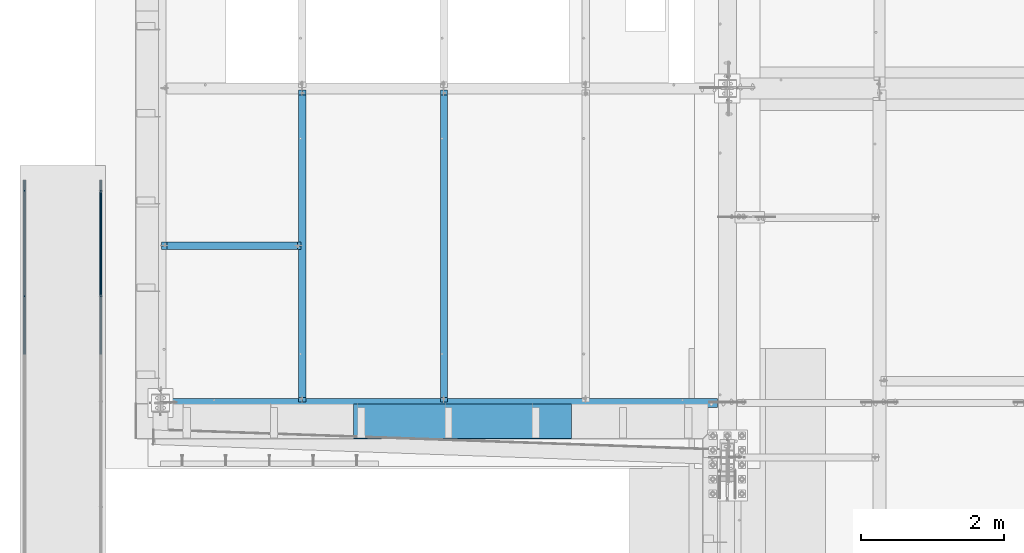
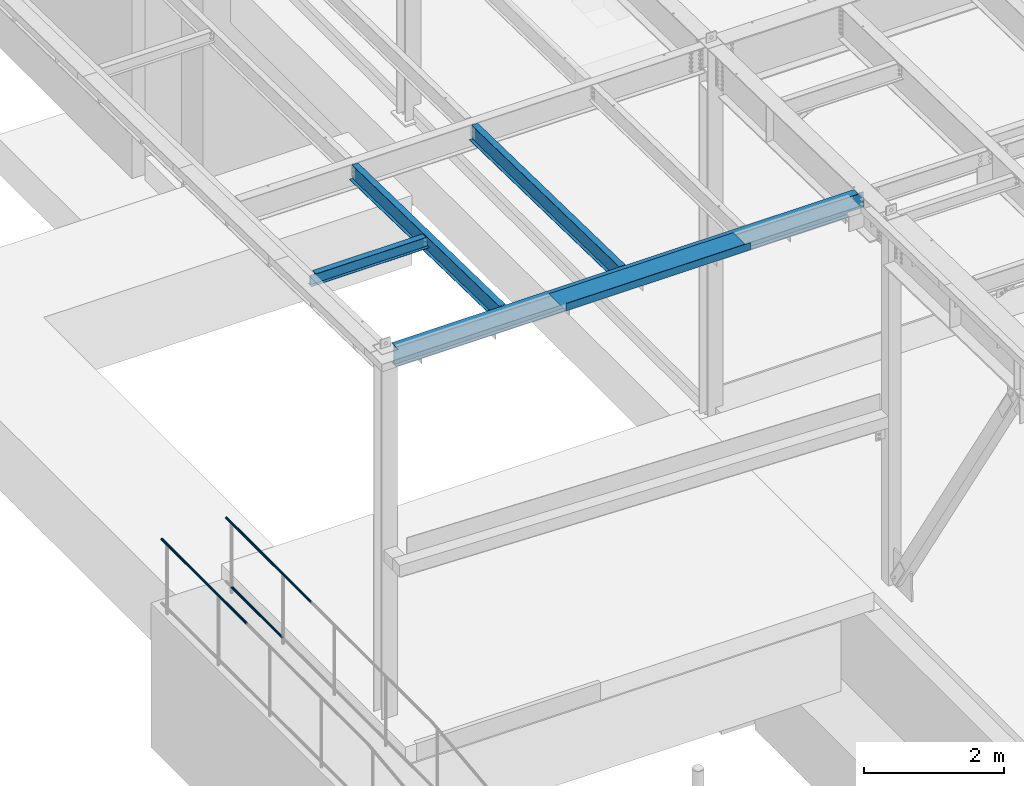
# One storey, part 1047 of 1763: 8 beams, 6 elements without a shape of their own.
"""IFC2X3 building model written with IfcOpenShell, lengths in millimetres."""

from ifc_helpers import new_model, si_unit, frame, origin_with_axes, place, context, subcontext, project, spatial, faceted_brep, material, type_object, element, aggregate, save


model = new_model("IFC2X3")

# Units and contexts
model_context = context("Model", 3, precision=1e-05, world=origin_with_axes())
body_context = subcontext(model_context, "Body", "Model", "MODEL_VIEW")
ifc_project = project(units=[si_unit("LENGTHUNIT", "METRE", prefix="MILLI"), si_unit("AREAUNIT", "SQUARE_METRE"), si_unit("VOLUMEUNIT", "CUBIC_METRE"), si_unit("MASSUNIT", "GRAM", prefix="KILO"), si_unit("TIMEUNIT", "SECOND"), si_unit("PLANEANGLEUNIT", "RADIAN"), si_unit("SOLIDANGLEUNIT", "STERADIAN"), si_unit("THERMODYNAMICTEMPERATUREUNIT", "DEGREE_CELSIUS"), si_unit("LUMINOUSINTENSITYUNIT", "LUMEN")], contexts=[model_context])

# Site, building, storey
site_placement = place(None, origin_with_axes())
site = spatial("IfcSite", under=ifc_project, at=site_placement, CompositionType="ELEMENT")
building_placement = place(site_placement, origin_with_axes())
building = spatial("IfcBuilding", under=site, at=building_placement, Name="Undefined", CompositionType="ELEMENT")
storey_placement = place(building_placement, origin_with_axes())
storey = spatial("IfcBuildingStorey", under=building, at=storey_placement, Name="Undefined", CompositionType="ELEMENT", Elevation=0.0)

# Assembly, beam
assembly_1_placement = place(storey_placement, origin_with_axes())
assembly_1 = element("IfcElementAssembly", 1, at=assembly_1_placement, inside=storey, Name="GUARDRAIL", AssemblyPlace="NOTDEFINED", PredefinedType="RIGID_FRAME")
ifc_material_1 = material(Name="STEEL/A513")
beam_type_1 = type_object("IfcBeamType", PredefinedType="NOTDEFINED")
beam_1_placement = place(assembly_1_placement, frame((-97200.6527017878, 12414.0437130928, 7149.43160350605), z_axis=(1.0, 0.0, 0.0), x_axis=(0.0, -1.0, 0.0)))
beam_1 = element("IfcBeam", 2, at=beam_1_placement, type_object=beam_type_1, material=ifc_material_1, Name="GUARDRAIL", context=body_context, shape_type="Brep", body=[
    faceted_brep([(0.0, -19.0500000000029, 0.0), (0.0, -16.4977839420899, -9.52500000000146), (2438.33764459851, -16.4980626778533, -9.52499999999418), (2438.33764430676, -19.05027873576, 0.0), (0.0, -9.52499999999418, -16.4977839420935), (2438.3376453956, -9.52527873575946, -16.4977839420899), (1.45519152283669e-11, 1.81898940354586e-12, -19.0499999999993), (2438.33764648444, -0.000278735759820847, -19.0500000000029), (0.0, 9.52499999999418, -16.4977839420935), (2438.33764757328, 9.52472126424072, -16.4977839420899), (0.0, 16.4977839420899, -9.52500000000146), (2438.33764837036, 16.4975052063346, -9.52499999999418), (0.0, 19.0500000000029, 0.0), (2438.33764866212, 19.0497212642413, 0.0), (0.0, 16.4977839420899, 9.52500000000146), (2438.33764837036, 16.4975052063346, 9.52499999999418), (0.0, 9.52499999999418, 16.4977839420935), (2438.33764757328, 9.52472126424072, 16.4977839420899), (1.45519152283669e-11, 1.81898940354586e-12, 19.0499999999993), (2438.33764648444, -0.000278735759820847, 19.0500000000029), (0.0, -9.52499999999418, 16.4977839420935), (2438.3376453956, -9.52527873575946, 16.4977839420899), (0.0, -16.4977839420899, 9.52500000000146), (2438.33764459851, -16.4980626778533, 9.52499999999418), (4.71409293822944e-08, -15.3669999999984, 0.0), (-1.81898940354586e-12, -13.3082123799541, 7.68349999999919), (2438.33764496312, -13.3084911157148, 7.68349999999919), (2438.33764472778, -15.36727873576, 0.0), (-3.63797880709171e-12, -7.68349999999919, 13.3082123799531), (2438.33764560611, -7.68377873575992, 13.3082123799541), (-1.81898940354586e-12, 0.0, 15.3669999999966), (2438.33764648444, -0.000278735759820847, 15.3669999999984), (-3.63797880709171e-12, 7.68349999999919, 13.3082123799531), (2438.33764736277, 7.68322126424027, 13.3082123799541), (-1.81898940354586e-12, 13.3082123799541, 7.68349999999919), (2438.33764800575, 13.3079336441961, 7.68349999999919), (4.71409293822944e-08, 15.3669999999984, 0.0), (2438.3376482411, 15.3667212642404, 0.0), (3.63797880709171e-12, 13.3082123799541, -7.68349999999737), (2438.33764800575, 13.3079336441961, -7.68349999999919), (3.63797880709171e-12, 7.68349999999919, -13.3082123799522), (2438.33764736277, 7.68322126424027, -13.3082123799541), (3.63797880709171e-12, 0.0, -15.3669999999956), (2438.33764648444, -0.000278735759820847, -15.3669999999984), (3.63797880709171e-12, -7.68349999999919, -13.3082123799522), (2438.33764560611, -7.68377873575992, -13.3082123799541), (3.63797880709171e-12, -13.3082123799541, -7.68349999999737), (2438.33764496312, -13.3084911157148, -7.68349999999919)], [[[0, 1, 2, 3]], [[1, 4, 5, 2]], [[4, 6, 7, 5]], [[6, 8, 9, 7]], [[8, 10, 11, 9]], [[10, 12, 13, 11]], [[12, 14, 15, 13]], [[14, 16, 17, 15]], [[16, 18, 19, 17]], [[18, 20, 21, 19]], [[20, 22, 23, 21]], [[22, 0, 3, 23]], [[24, 25, 26, 27]], [[25, 28, 29, 26]], [[28, 30, 31, 29]], [[30, 32, 33, 31]], [[32, 34, 35, 33]], [[34, 36, 37, 35]], [[36, 38, 39, 37]], [[38, 40, 41, 39]], [[40, 42, 43, 41]], [[42, 44, 45, 43]], [[44, 46, 47, 45]], [[46, 24, 27, 47]], [[5, 7, 9, 11, 13, 15, 17, 19, 21, 23, 3, 2], [29, 31, 33, 35, 37, 39, 41, 43, 45, 47, 27, 26]], [[22, 20, 18, 16, 14, 12, 10, 8, 6, 4, 1, 0], [46, 44, 42, 40, 38, 36, 34, 32, 30, 28, 25, 24]]]),
])
aggregate(assembly_1, [beam_1])

# Assembly, beams
assembly_2_placement = place(storey_placement, origin_with_axes())
assembly_2 = element("IfcElementAssembly", 3, at=assembly_2_placement, inside=storey, Name="GUARDRAIL", AssemblyPlace="NOTDEFINED", PredefinedType="RIGID_FRAME")
beam_2_placement = place(assembly_2_placement, frame((-96133.8527017878, 10786.2772271783, 6031.68570659609), z_axis=(0.0, -4.62400000105845e-06, 0.999999999989309), x_axis=(0.0, 0.999999999989309, 4.62400000047487e-06)))
beam_2 = element("IfcBeam", 4, at=beam_2_placement, type_object=beam_type_1, material=ifc_material_1, Name="GUARDRAIL", context=body_context, shape_type="Brep", body=[
    faceted_brep([(2.16604427796847, 19.0500000000029, 0.0), (11.6909965485302, 16.4977839420899, -9.524999999996), (11.6910920080991, 16.4977839420899, 9.52499999999964), (11.6910920080991, -16.4977839420899, 9.52499999999964), (11.6909965485302, -16.4977839420899, -9.524999999996), (2.16604427796847, -19.0500000000029, 0.0), (18.6639108909039, -9.52499999999418, 16.4977839420944), (18.6638856802001, -9.52499999999418, 11.4667123799572), (14.8806543426199, -13.3082123799541, 7.683500000001), (12.8218282205307, -15.3669999999984, 1.81898940354586e-12), (14.8805773385811, -13.3082123799541, -7.68349999999464), (18.6637707607879, -9.52499999999418, -11.4667123799491), (18.6637455500822, -9.52499999999418, -16.4977839420862), (21.2159672743801, 0.0, -15.366999999992), (21.2159488188627, 0.0, -19.049999999992), (19.1571899710179, -7.68349999999919, -13.3082123799486), (19.1571899710161, 7.68349999999919, -13.3082123799486), (18.6637707607879, 9.52499999999418, -11.4667123799491), (18.6637455500822, 9.52499999999418, -16.4977839420862), (14.8805773385793, 13.3082123799541, -7.68349999999464), (12.8218282205289, 15.3669999999984, 1.81898940354586e-12), (14.8806543426181, 13.3082123799541, 7.683500000001), (18.6638856802001, 9.52499999999418, 11.4667123799572), (18.6639108909039, 9.52499999999418, 16.4977839420944), (19.1573233459221, 7.68349999999919, 13.3082123799568), (21.2161212824831, 0.0, 15.367000000002), (21.2161397379987, 0.0, 19.0500000000002), (19.1573233459239, -7.68349999999919, 13.3082123799568), (1475.3660442957, 19.0500000000029, 3.11956682708114e-10), (1465.84099656603, 16.4977839420899, -9.52499999968768), (1458.86817768322, 9.52499999999418, -16.4977839417807), (1475.36604429593, -19.0500000000029, 3.11956682708114e-10), (1465.84099656603, -16.4977839420899, -9.52499999968768), (1465.8410920256, -16.4977839420899, 9.52500000030795), (1458.86834302404, -9.52499999999418, 16.4977839423982), (1458.86817768322, -9.52499999999418, -16.4977839417807), (1456.31594883613, 0.0, -19.0499999996873), (1458.37476522842, 7.68349999999919, -13.308212379643), (1456.31596729164, 0.0, -15.3669999996882), (1458.86820289393, 9.52499999999418, -11.4667123796444), (1458.86820289393, -9.52499999999418, -11.4667123796444), (1458.37476522842, -7.68349999999919, -13.308212379643), (1462.65143423172, -13.3082123799541, -7.68349999968814), (1464.71026035381, -15.3669999999984, 3.09228198602796e-10), (1462.65151123576, -13.3082123799541, 7.6835000003075), (1458.86831781334, -9.52499999999418, 11.4667123802628), (1458.37489860333, -7.68349999999919, 13.3082123802624), (1456.31612129975, 0.0, 15.3670000003058), (1456.31613975526, 0.0, 19.050000000304), (1458.86834302404, 9.52499999999418, 16.4977839423982), (1465.8410920256, 16.4977839420899, 9.52500000030795), (1458.86831781334, 9.52499999999418, 11.4667123802628), (1462.65151123576, 13.3082123799541, 7.6835000003075), (1464.71026035381, 15.3669999999984, 3.09228198602796e-10), (1462.65143423172, 13.3082123799541, -7.68349999968814), (1458.37489860332, 7.68349999999919, 13.3082123802624)], [[[0, 1, 2]], [[3, 4, 5]], [[6, 7, 8, 9, 10, 11, 12, 4, 3]], [[13, 14, 12, 11, 15]], [[16, 17, 18, 14, 13]], [[2, 1, 18, 17, 19, 20, 21, 22, 23]], [[23, 22, 24, 25, 26]], [[26, 25, 27, 7, 6]], [[1, 0, 28, 29]], [[18, 1, 29, 30]], [[31, 32, 33]], [[6, 3, 33, 34]], [[3, 5, 31, 33]], [[5, 4, 32, 31]], [[4, 12, 35, 32]], [[12, 14, 36, 35]], [[14, 18, 30, 36]], [[37, 38, 36, 30, 39]], [[40, 35, 36, 38, 41]], [[33, 32, 35, 40, 42, 43, 44, 45, 34]], [[34, 45, 46, 47, 48]], [[26, 6, 34, 48]], [[2, 23, 49, 50]], [[23, 26, 48, 49]], [[0, 2, 50, 28]], [[28, 50, 29]], [[49, 51, 52, 53, 54, 39, 30, 29, 50]], [[48, 47, 55, 51, 49]], [[25, 24, 55, 47]], [[55, 24, 22, 21, 52, 51]], [[21, 20, 53, 52]], [[20, 19, 54, 53]], [[19, 17, 16, 37, 39, 54]], [[16, 13, 38, 37]], [[13, 15, 41, 38]], [[41, 15, 11, 10, 42, 40]], [[10, 9, 43, 42]], [[9, 8, 44, 43]], [[8, 7, 27, 46, 45, 44]], [[27, 25, 47, 46]]]),
])
beam_3_placement = place(assembly_2_placement, frame((-96133.8527017878, 12414.0437130928, 7149.43160350605), z_axis=(1.0, 0.0, 0.0), x_axis=(0.0, -1.0, 0.0)))
beam_3 = element("IfcBeam", 5, at=beam_3_placement, type_object=beam_type_1, material=ifc_material_1, Name="GUARDRAIL", context=body_context, shape_type="Brep", body=[
    faceted_brep([(0.0, -19.0500000000029, 0.0), (0.0, -16.4977839420899, -9.52500000000146), (2438.33764459851, -16.4980626778533, -9.52499999999418), (2438.33764430676, -19.05027873576, 0.0), (0.0, -9.52499999999418, -16.4977839420935), (2438.3376453956, -9.52527873575946, -16.4977839420899), (1.45519152283669e-11, 1.81898940354586e-12, -19.0499999999993), (2438.33764648444, -0.000278735759820847, -19.0500000000029), (0.0, 9.52499999999418, -16.4977839420935), (2438.33764757328, 9.52472126424072, -16.4977839420899), (0.0, 16.4977839420899, -9.52500000000146), (2438.33764837036, 16.4975052063346, -9.52499999999418), (0.0, 19.0500000000029, 0.0), (2438.33764866212, 19.0497212642413, 0.0), (0.0, 16.4977839420899, 9.52500000000146), (2438.33764837036, 16.4975052063346, 9.52499999999418), (0.0, 9.52499999999418, 16.4977839420935), (2438.33764757328, 9.52472126424072, 16.4977839420899), (1.45519152283669e-11, 1.81898940354586e-12, 19.0499999999993), (2438.33764648444, -0.000278735759820847, 19.0500000000029), (0.0, -9.52499999999418, 16.4977839420935), (2438.3376453956, -9.52527873575946, 16.4977839420899), (0.0, -16.4977839420899, 9.52500000000146), (2438.33764459851, -16.4980626778533, 9.52499999999418), (4.71409293822944e-08, -15.3669999999984, 0.0), (-1.81898940354586e-12, -13.3082123799541, 7.68349999999919), (2438.33764496312, -13.3084911157148, 7.68349999999919), (2438.33764472778, -15.36727873576, 0.0), (-3.63797880709171e-12, -7.68349999999919, 13.3082123799531), (2438.33764560611, -7.68377873575992, 13.3082123799541), (-1.81898940354586e-12, 0.0, 15.3669999999966), (2438.33764648444, -0.000278735759820847, 15.3669999999984), (-3.63797880709171e-12, 7.68349999999919, 13.3082123799531), (2438.33764736277, 7.68322126424027, 13.3082123799541), (-1.81898940354586e-12, 13.3082123799541, 7.68349999999919), (2438.33764800575, 13.3079336441961, 7.68349999999919), (4.71409293822944e-08, 15.3669999999984, 0.0), (2438.3376482411, 15.3667212642404, 0.0), (3.63797880709171e-12, 13.3082123799541, -7.68349999999737), (2438.33764800575, 13.3079336441961, -7.68349999999919), (3.63797880709171e-12, 7.68349999999919, -13.3082123799522), (2438.33764736277, 7.68322126424027, -13.3082123799541), (3.63797880709171e-12, 0.0, -15.3669999999956), (2438.33764648444, -0.000278735759820847, -15.3669999999984), (3.63797880709171e-12, -7.68349999999919, -13.3082123799522), (2438.33764560611, -7.68377873575992, -13.3082123799541), (3.63797880709171e-12, -13.3082123799541, -7.68349999999737), (2438.33764496312, -13.3084911157148, -7.68349999999919)], [[[0, 1, 2, 3]], [[1, 4, 5, 2]], [[4, 6, 7, 5]], [[6, 8, 9, 7]], [[8, 10, 11, 9]], [[10, 12, 13, 11]], [[12, 14, 15, 13]], [[14, 16, 17, 15]], [[16, 18, 19, 17]], [[18, 20, 21, 19]], [[20, 22, 23, 21]], [[22, 0, 3, 23]], [[24, 25, 26, 27]], [[25, 28, 29, 26]], [[28, 30, 31, 29]], [[30, 32, 33, 31]], [[32, 34, 35, 33]], [[34, 36, 37, 35]], [[36, 38, 39, 37]], [[38, 40, 41, 39]], [[40, 42, 43, 41]], [[42, 44, 45, 43]], [[44, 46, 47, 45]], [[46, 24, 27, 47]], [[5, 7, 9, 11, 13, 15, 17, 19, 21, 23, 3, 2], [29, 31, 33, 35, 37, 39, 41, 43, 45, 47, 27, 26]], [[22, 20, 18, 16, 14, 12, 10, 8, 6, 4, 1, 0], [46, 44, 42, 40, 38, 36, 34, 32, 30, 28, 25, 24]]]),
])
aggregate(assembly_2, [beam_2, beam_3])

# Assembly, beam
assembly_3_placement = place(storey_placement, origin_with_axes())
assembly_3 = element("IfcElementAssembly", 6, at=assembly_3_placement, inside=storey, Name="BEAM", AssemblyPlace="NOTDEFINED", PredefinedType="RIGID_FRAME")
ifc_material_2 = material(Name="STEEL/A992")
beam_type_2 = type_object("IfcBeamType", Name="W8X10", PredefinedType="NOTDEFINED")
beam_4_placement = place(assembly_3_placement, frame((-95300.2372736984, 11493.4566102734, 11577.6605400897), z_axis=(0.0, 0.0, 1.0), x_axis=(1.0, 0.0, 0.0)))
beam_4 = element("IfcBeam", 7, at=beam_4_placement, type_object=beam_type_2, material=ifc_material_2, Name="BEAM", ObjectType="W8X10", context=body_context, shape_type="Brep", body=[
    faceted_brep([(80.168750190729, -2.38125000000036, 68.0025016784894), (80.168750190729, 2.38125000000036, 68.0025016784894), (16.6687499999971, 2.38125000000036, 68.0025016784894), (16.6687499999971, -2.38125000000036, 68.0025016784894), (85.0288297087682, -2.38125000000036, 68.9692316010769), (85.0288297087682, 2.38125000000036, 68.9692316010769), (89.1490061769291, -2.38125000000036, 71.7222455015544), (89.1490061769291, 2.38125000000036, 71.7222455015544), (91.9020200774103, -2.38125000000036, 75.8424219697081), (91.9020200774103, 2.38125000000036, 75.8424219697081), (92.8687499999942, -2.38125000000036, 80.7025014877545), (92.8687499999942, 2.38125000000036, 80.7025014877545), (92.8687499999942, -50.7999999999993, 100.012500000001), (92.8687499999942, 50.7999999999993, 100.012500000001), (92.8687499999942, 50.7999999999993, 95.25), (92.8687499999942, 2.38125000000036, 95.25), (92.8687499999942, -2.38125000000036, 95.25), (92.8687499999942, -50.7999999999993, 95.25), (16.6687500075204, -2.38124999999854, -95.25), (16.6687500075204, -50.8000000000029, -95.25), (1966.11874999999, -50.7999999999993, -95.25), (1966.11874999999, -2.38125000000036, -95.25), (16.6687500075204, -50.8000000000029, -100.012500000001), (1966.11874999999, -50.7999999999993, -100.012500000001), (16.6687500075204, 50.8000000000029, -100.012500000001), (1966.11874999999, 50.7999999999993, -100.012500000001), (16.6687500075204, 50.8000000000029, -95.25), (1966.11874999999, 50.7999999999993, -95.25), (16.6687500075204, 2.38124999999854, -95.25), (1966.11874999999, 2.38125000000036, -95.25), (1966.11874999999, 2.38125000000036, 74.3525016799649), (1966.11874999999, -2.38125000000036, 74.3525016799649), (1928.01874980926, 2.38125000000036, 74.3525016799649), (1928.01874980926, -2.38125000000036, 74.3525016799649), (1923.15867029122, 2.38125000000036, 75.3192316025525), (1923.15867029122, -2.38125000000036, 75.3192316025525), (1919.03849382306, 2.38125000000036, 78.07224550303), (1919.03849382306, -2.38125000000036, 78.07224550303), (1916.28547992258, 2.38125000000036, 82.1924219711836), (1916.28547992258, -2.38125000000036, 82.1924219711836), (1915.31874999999, 2.38125000000036, 87.0525014892301), (1915.31874999999, -2.38125000000036, 87.0525014892301), (1915.31874999999, -50.7999999999993, 100.012500000001), (1915.31874999999, -50.7999999999993, 95.25), (1915.31874999999, -2.38125000000036, 95.25), (1915.31874999999, 2.38125000000036, 95.25), (1915.31874999999, 50.7999999999993, 95.25), (1915.31874999999, 50.7999999999993, 100.012500000001)], [[[0, 1, 2, 3]], [[4, 5, 1, 0]], [[6, 7, 5, 4]], [[8, 9, 7, 6]], [[10, 11, 9, 8]], [[12, 13, 14, 15, 11, 10, 16, 17]], [[18, 19, 20, 21]], [[19, 22, 23, 20]], [[22, 24, 25, 23]], [[24, 26, 27, 25]], [[26, 28, 29, 27]], [[21, 20, 23, 25, 27, 29, 30, 31]], [[31, 30, 32, 33]], [[33, 32, 34, 35]], [[35, 34, 36, 37]], [[37, 36, 38, 39]], [[39, 38, 40, 41]], [[42, 43, 44, 41, 40, 45, 46, 47]], [[43, 42, 12, 17]], [[44, 43, 17, 16]], [[8, 6, 4, 0, 3, 18, 21, 31, 33, 35, 37, 39, 41, 44, 16, 10]], [[28, 26, 24, 22, 19, 18, 3, 2]], [[45, 40, 38, 36, 34, 32, 30, 29, 28, 2, 1, 5, 7, 9, 11, 15]], [[46, 45, 15, 14]], [[47, 46, 14, 13]], [[42, 47, 13, 12]]]),
])
aggregate(assembly_3, [beam_4])

# Assembly, beams
assembly_4_placement = place(storey_placement, origin_with_axes())
assembly_4 = element("IfcElementAssembly", 8, at=assembly_4_placement, inside=storey, Name="BEAM", AssemblyPlace="NOTDEFINED", PredefinedType="RIGID_FRAME")
beam_type_3 = type_object("IfcBeamType", Name="W14X22", PredefinedType="NOTDEFINED")
beam_5_placement = place(assembly_4_placement, frame((-95300.2372736984, 9296.4, 11547.3920365109), z_axis=(0.0, 0.0, 1.0), x_axis=(1.0, 0.0, 0.0)))
beam_5 = element("IfcBeam", 9, at=beam_5_placement, type_object=beam_type_3, material=ifc_material_2, Name="BEAM", ObjectType="W14X22", context=body_context, shape_type="Brep", body=[
    faceted_brep([(7639.05000000002, -3.17499999999927, -166.6875), (7639.05000000002, -63.5, -166.6875), (7639.05000000002, -63.5, -174.625), (7639.05000000002, 63.5, -174.625), (7639.05000000002, 63.5, -166.6875), (7639.05000000002, 3.17499999999927, -166.6875), (7639.05000000002, 3.17499999999927, -149.224999807899), (7639.05000000002, -3.17499999999927, -149.224999807899), (7640.0167299226, 3.17499999999927, -144.364920289852), (7640.0167299226, -3.17499999999927, -144.364920289852), (7642.76974382308, 3.17499999999927, -140.244743821699), (7642.76974382308, -3.17499999999927, -140.244743821699), (7646.88992029124, 3.17499999999927, -137.491729921221), (7646.88992029124, -3.17499999999927, -137.491729921221), (7651.74999980928, 3.17499999999927, -136.524999998634), (7651.74999980928, -3.17499999999927, -136.524999998634), (7905.75, -3.17499999999927, -136.524999998634), (7905.75, 3.17499999999927, -136.524999998634), (139.699999999997, 3.17499999999927, 166.6875), (139.699999999997, 63.5, 166.6875), (7785.10000000002, 63.5, 166.6875), (7785.10000000002, 3.17499999999927, 166.6875), (139.699999999997, -63.5, -174.625), (139.699999999997, -63.5, -166.6875), (139.699999999997, -3.17499999999927, -166.6875), (139.699999999997, -3.17499999999927, 166.6875), (139.699999999997, -63.5, 166.6875), (139.699999999997, -63.5, 174.625), (139.699999999997, 63.5, 174.625), (139.699999999997, 3.17499999999927, -166.6875), (139.699999999997, 63.5, -166.6875), (139.699999999997, 63.5, -174.625), (7785.10000000002, -3.17499999999927, 166.6875), (7785.10000000002, -63.5, 166.6875), (7785.10000000002, -63.5, 174.625), (7785.10000000002, 63.5, 174.625), (7785.10000000002, -3.17499999999927, 149.224999810631), (7785.10000000002, 3.17499999999927, 149.224999810631), (7786.0667299226, -3.17499999999927, 144.364920292584), (7786.0667299226, 3.17499999999927, 144.364920292584), (7788.81974382309, -3.17499999999927, 140.244743824431), (7788.81974382309, 3.17499999999927, 140.244743824431), (7792.93992029125, -3.17499999999927, 137.491729923953), (7792.93992029125, 3.17499999999927, 137.491729923953), (7797.79999980929, -3.17499999999927, 136.525000001366), (7797.79999980929, 3.17499999999927, 136.525000001366), (7905.75, -3.17499999999927, 136.525000001366), (7905.75, 3.17499999999927, 136.525000001366)], [[[0, 1, 2, 3, 4, 5, 6, 7]], [[7, 6, 8, 9]], [[9, 8, 10, 11]], [[11, 10, 12, 13]], [[13, 12, 14, 15]], [[16, 15, 14, 17]], [[18, 19, 20, 21]], [[22, 23, 24, 25, 26, 27, 28, 19, 18, 29, 30, 31]], [[26, 25, 32, 33]], [[27, 26, 33, 34]], [[28, 27, 34, 35]], [[19, 28, 35, 20]], [[34, 33, 32, 36, 37, 21, 20, 35]], [[38, 39, 37, 36]], [[40, 41, 39, 38]], [[42, 43, 41, 40]], [[44, 45, 43, 42]], [[46, 47, 45, 44]], [[47, 46, 16, 17]], [[12, 10, 8, 6, 5, 29, 18, 21, 37, 39, 41, 43, 45, 47, 17, 14]], [[30, 29, 5, 4]], [[31, 30, 4, 3]], [[22, 31, 3, 2]], [[23, 22, 2, 1]], [[24, 23, 1, 0]], [[46, 44, 42, 40, 38, 36, 32, 25, 24, 0, 7, 9, 11, 13, 15, 16]]]),
])
ifc_material_3 = material(Name="STEEL/A36")
beam_type_4 = type_object("IfcBeamType", PredefinedType="NOTDEFINED")
beam_6_placement = place(assembly_4_placement, frame((-91077.4872736984, 9283.7, 11725.1920365109), z_axis=(-1.0, 0.0, 0.0), x_axis=(0.0, -1.0, 0.0)))
beam_6 = element("IfcBeam", 10, at=beam_6_placement, type_object=beam_type_4, material=ifc_material_3, Name="BENT_PLATE", context=body_context, shape_type="Brep", body=[
    faceted_brep([(0.0, -3.17499999999927, -1523.99999999999), (0.0, -3.17499999999927, 1524.0), (0.0, 3.17499999999927, 1524.0), (0.0, 3.17499999999927, -1523.99999999999), (482.600012207033, 3.17499999999927, 1524.0), (482.600012207033, 3.17499999999927, -1524.0), (488.950012207031, -3.17499999999927, -1524.0), (488.950012207031, -3.17499999999927, 1524.0), (482.600012207033, 123.825000000001, 1524.0), (482.600012207033, 123.825000000001, -1524.0), (488.950012207031, 123.825000000001, 1524.0), (488.950012207031, 123.825000000001, -1524.0)], [[[0, 1, 2, 3]], [[3, 2, 4, 5]], [[1, 0, 6, 7]], [[5, 4, 8, 9]], [[4, 2, 1, 7, 10, 8]], [[7, 6, 11, 10]], [[6, 0, 3, 5, 9, 11]], [[10, 11, 9, 8]]]),
])
aggregate(assembly_4, [beam_6, beam_5])

# Assembly, beam
assembly_5_placement = place(storey_placement, origin_with_axes())
assembly_5 = element("IfcElementAssembly", 11, at=assembly_5_placement, inside=storey, Name="BEAM", AssemblyPlace="NOTDEFINED", PredefinedType="RIGID_FRAME")
beam_type_5 = type_object("IfcBeamType", Name="W12X14", PredefinedType="NOTDEFINED")
beam_7_placement = place(assembly_5_placement, frame((-91337.8372736984, 9293.30302014747, 11571.2363385683), z_axis=(0.0, 0.0205353000101332, 0.999789128493351), x_axis=(0.0, 0.999789128493351, -0.020535300010126)))
beam_7 = element("IfcBeam", 12, at=beam_7_placement, type_object=beam_type_5, material=ifc_material_2, Name="BEAM", ObjectType="W12X14", context=body_context, shape_type="Brep", body=[
    faceted_brep([(63.4259815374699, -2.38125000000582, 118.802501677881), (63.4259815374699, 2.38125000000582, 118.802501677881), (16.5358217722533, 2.38125000000582, 118.802501677923), (16.5358217722533, -2.38125000000582, 118.802501677923), (68.2860610555108, -2.38125000000582, 119.769231600463), (68.2860610555108, 2.38125000000582, 119.769231600463), (72.4062375236626, -2.38125000000582, 122.522245500933), (72.4062375236626, 2.38125000000582, 122.522245500933), (75.159251424142, -2.38125000000582, 126.642421969082), (75.159251424142, 2.38125000000582, 126.642421969082), (76.1259813467314, -2.38125000000582, 131.502501487119), (76.1259813467314, 2.38125000000582, 131.502501487119), (76.125981346735, -2.38125000000582, 136.115030075191), (76.125981346735, 2.38125000000582, 136.115030075191), (21.9431878233027, -2.38125000000582, -144.46249999996), (21.9431878233027, -50.8000000000029, -144.46249999996), (4384.51938082993, -50.8000000000029, -144.462500003925), (4384.51938082993, -2.38125000000582, -144.462500003925), (22.0736144816328, -50.8000000000029, -150.812499999958), (4384.64980748826, -50.8000000000029, -150.812500003922), (22.0736144816328, 50.8000000000029, -150.812499999958), (4384.64980748826, 50.8000000000029, -150.812500003922), (21.9431878233027, 50.8000000000029, -144.46249999996), (4384.51938082993, 50.8000000000029, -144.462500003925), (21.9431878233027, 2.38125000000582, -144.46249999996), (4384.51938082993, 2.38125000000582, -144.462500003925), (4379.11201478, 2.38125000000582, 118.802501619442), (4379.11201478, -2.38125000000582, 118.802501619442), (4318.05217416162, 2.38125000000582, 118.802501619499), (4318.05217416162, -2.38125000000582, 118.802501619499), (4313.19209464358, 2.38125000000582, 119.76923154209), (4313.19209464358, -2.38125000000582, 119.76923154209), (4309.07191817543, 2.38125000000582, 122.522245442568), (4309.07191817543, -2.38125000000582, 122.522245442568), (4306.31890427496, 2.38125000000582, 126.642421910721), (4306.31890427496, -2.38125000000582, 126.642421910721), (4305.35217435238, 2.38125000000582, 131.50250142876), (4305.35217435238, -2.38125000000582, 131.50250142876), (4305.35217435239, -50.8000000000029, 150.812499996026), (4305.35217435239, -50.8000000000029, 144.462499996029), (4305.35217435239, -2.38125000000582, 144.462499996029), (4305.35217435239, 2.38125000000582, 144.462499996029), (4305.35217435239, 50.8000000000029, 144.462499996029), (4305.35217435239, 50.8000000000029, 150.812499996026), (76.3465351600425, 2.38125000000582, 144.462500000098), (76.3465351600425, 50.8000000000029, 144.462500000098), (76.2160766299548, 50.8000000000029, 150.8125000001), (76.2160766299548, -50.8000000000029, 150.8125000001), (76.3465351600425, -50.8000000000029, 144.462500000098), (76.3465351600425, -2.38125000000582, 144.462500000098), (76.4773265625245, 2.38125000000582, 138.09280243403), (76.4773265625245, -2.38125000000582, 138.09280243403)], [[[0, 1, 2, 3]], [[4, 5, 1, 0]], [[6, 7, 5, 4]], [[8, 9, 7, 6]], [[10, 11, 9, 8]], [[12, 13, 11, 10]], [[14, 15, 16, 17]], [[15, 18, 19, 16]], [[18, 20, 21, 19]], [[20, 22, 23, 21]], [[22, 24, 25, 23]], [[17, 16, 19, 21, 23, 25, 26, 27]], [[27, 26, 28, 29]], [[29, 28, 30, 31]], [[31, 30, 32, 33]], [[33, 32, 34, 35]], [[35, 34, 36, 37]], [[38, 39, 40, 37, 36, 41, 42, 43]], [[42, 41, 44, 45]], [[43, 42, 45, 46]], [[38, 43, 46, 47]], [[39, 38, 47, 48]], [[40, 39, 48, 49]], [[47, 46, 45, 44, 50, 51, 49, 48]], [[8, 6, 4, 0, 3, 14, 17, 27, 29, 31, 33, 35, 37, 40, 49, 51, 12, 10]], [[24, 22, 20, 18, 15, 14, 3, 2]], [[50, 44, 41, 36, 34, 32, 30, 28, 26, 25, 24, 2, 1, 5, 7, 9, 11, 13]], [[51, 50, 13, 12]]]),
])
aggregate(assembly_5, [beam_7])

assembly_6_placement = place(storey_placement, origin_with_axes())
assembly_6 = element("IfcElementAssembly", 13, at=assembly_6_placement, inside=storey, Name="BEAM", AssemblyPlace="NOTDEFINED", PredefinedType="RIGID_FRAME")
beam_8_placement = place(assembly_6_placement, frame((-93319.0372736984, 9293.33696941504, 11571.2356285529), z_axis=(0.0, 0.0205403160093265, 0.999789025453989), x_axis=(0.0, 0.999789025516018, -0.0205403129900748)))
beam_8 = element("IfcBeam", 14, at=beam_8_placement, type_object=beam_type_5, material=ifc_material_2, Name="BEAM", ObjectType="W12X14", context=body_context, shape_type="Brep", body=[
    faceted_brep([(63.3920270601557, -2.38125000000582, 118.802501678625), (63.3920270601557, 2.38125000000582, 118.802501678625), (16.5012713637025, 2.38125000000582, 118.802501678594), (16.5012713637025, -2.38125000000582, 118.802501678594), (68.2521065782057, -2.38125000000582, 119.769231601216), (68.2521065782057, 2.38125000000582, 119.769231601216), (72.3722830463594, -2.38125000000582, 122.522245501701), (72.3722830463594, 2.38125000000582, 122.522245501701), (75.1252969468369, -2.38125000000582, 126.64242196986), (75.1252969468369, 2.38125000000582, 126.64242196986), (76.0920268694226, -2.38125000000582, 131.502501487908), (76.0920268694226, 2.38125000000582, 131.502501487908), (76.092026869419, -2.38125000000582, 136.119278686343), (76.092026869419, 2.38125000000582, 136.119278686343), (21.9099579923804, -2.38125000000582, -144.462500000023), (21.9099579923804, -50.8000000000029, -144.462500000023), (4384.48660034598, -50.8000000000029, -144.46249999712), (4384.48660034598, -2.38125000000582, -144.46249999712), (22.0404165032833, -50.8000000000029, -150.812500000025), (4384.61705885688, -50.8000000000029, -150.812499997122), (22.0404165032833, 50.8000000000029, -150.812500000025), (4384.61705885688, 50.8000000000029, -150.812499997122), (21.9099579923804, 50.8000000000029, -144.462500000023), (4384.48660034598, 50.8000000000029, -144.46249999712), (21.9099579923804, 2.38125000000582, -144.462500000023), (4384.48660034598, 2.38125000000582, -144.46249999712), (4379.07791371646, 2.38125000000582, 118.802501722324), (4379.07791371646, -2.38125000000582, 118.802501722324), (4318.01866903349, 2.38125000000582, 118.802501722283), (4318.01866903349, -2.38125000000582, 118.802501722283), (4313.15858951544, 2.38125000000582, 119.769231644868), (4313.15858951544, -2.38125000000582, 119.769231644868), (4309.03841304728, 2.38125000000582, 122.522245545346), (4309.03841304728, -2.38125000000582, 122.522245545346), (4306.2853991468, 2.38125000000582, 126.642422013503), (4306.2853991468, -2.38125000000582, 126.642422013503), (4305.31866922421, 2.38125000000582, 131.50250153155), (4305.31866922421, -2.38125000000582, 131.50250153155), (4305.31866922419, -50.8000000000029, 150.812500002903), (4305.3186692242, -50.8000000000029, 144.462500002905), (4305.3186692242, -2.38125000000582, 144.462500002905), (4305.3186692242, 2.38125000000582, 144.462500002905), (4305.3186692242, 50.8000000000029, 144.462500002905), (4305.31866922419, 50.8000000000029, 150.812500002903), (76.3118224153022, 2.38125000000582, 144.462500000089), (76.3118224153022, 50.8000000000029, 144.462500000089), (76.1813639043994, 50.8000000000029, 150.812500000091), (76.1813639043994, -50.8000000000029, 150.812500000091), (76.3118224153022, -50.8000000000029, 144.462500000089), (76.3118224153022, -2.38125000000582, 144.462500000089), (76.4426774701697, 2.38125000000582, 138.093198429517), (76.4426774701697, -2.38125000000582, 138.093198429517)], [[[0, 1, 2, 3]], [[4, 5, 1, 0]], [[6, 7, 5, 4]], [[8, 9, 7, 6]], [[10, 11, 9, 8]], [[12, 13, 11, 10]], [[14, 15, 16, 17]], [[15, 18, 19, 16]], [[18, 20, 21, 19]], [[20, 22, 23, 21]], [[22, 24, 25, 23]], [[17, 16, 19, 21, 23, 25, 26, 27]], [[27, 26, 28, 29]], [[29, 28, 30, 31]], [[31, 30, 32, 33]], [[33, 32, 34, 35]], [[35, 34, 36, 37]], [[38, 39, 40, 37, 36, 41, 42, 43]], [[42, 41, 44, 45]], [[43, 42, 45, 46]], [[38, 43, 46, 47]], [[39, 38, 47, 48]], [[40, 39, 48, 49]], [[47, 46, 45, 44, 50, 51, 49, 48]], [[8, 6, 4, 0, 3, 14, 17, 27, 29, 31, 33, 35, 37, 40, 49, 51, 12, 10]], [[24, 22, 20, 18, 15, 14, 3, 2]], [[50, 44, 41, 36, 34, 32, 30, 28, 26, 25, 24, 2, 1, 5, 7, 9, 11, 13]], [[51, 50, 13, 12]]]),
])
aggregate(assembly_6, [beam_8])

save(model, "model.ifc")
